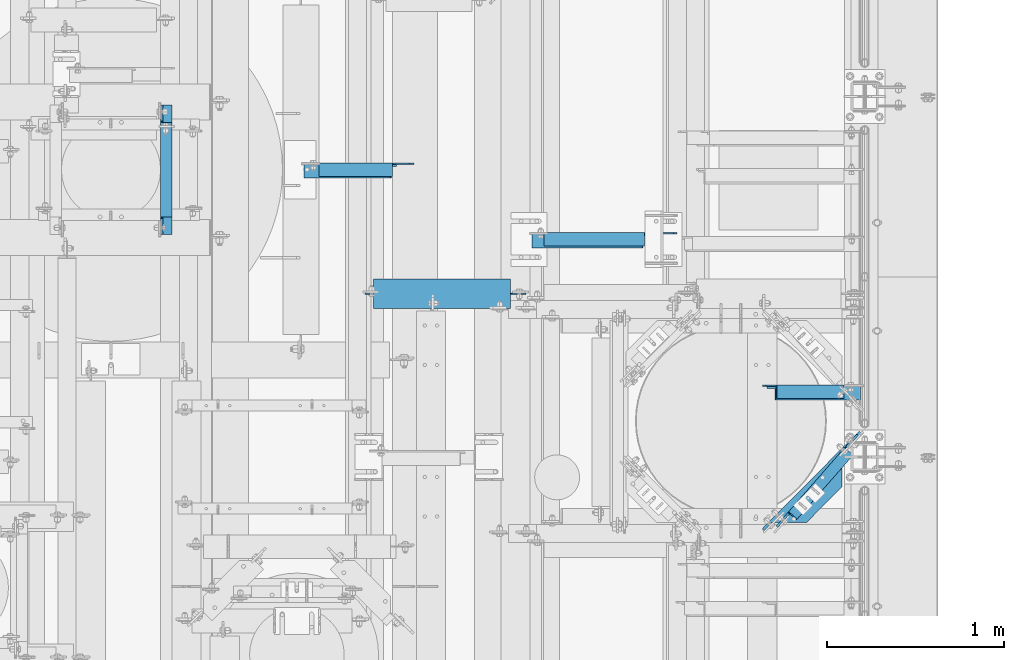
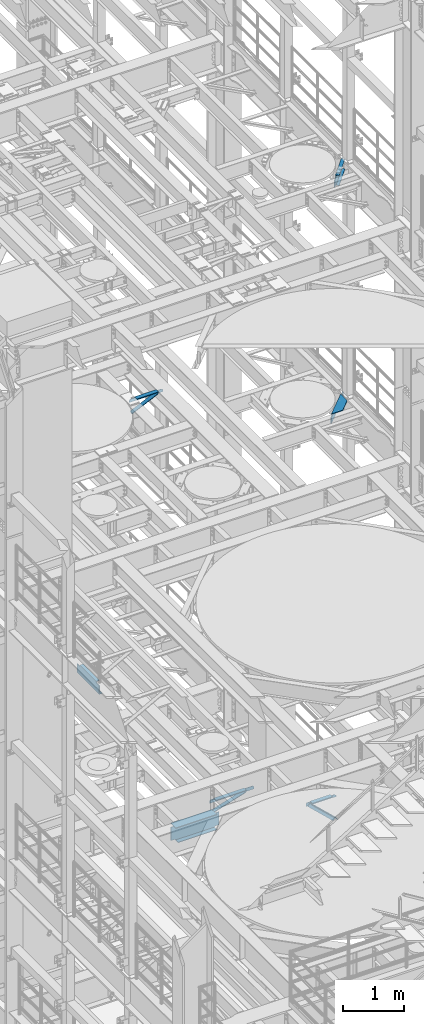
# One storey, part 1261 of 1876: 8 beams, 2 members, 10 elements without a shape of their own.
"""IFC2X3 building model written with IfcOpenShell, lengths in millimetres."""

from ifc_helpers import new_model, si_unit, frame, origin_with_axes, place, context, subcontext, project, spatial, faceted_brep, material, type_object, element, aggregate, save


model = new_model("IFC2X3")

# Units and contexts
model_context = context("Model", 3, precision=1e-05, world=origin_with_axes())
body_context = subcontext(model_context, "Body", "Model", "MODEL_VIEW")
ifc_project = project(units=[si_unit("LENGTHUNIT", "METRE", prefix="MILLI"), si_unit("AREAUNIT", "SQUARE_METRE"), si_unit("VOLUMEUNIT", "CUBIC_METRE"), si_unit("MASSUNIT", "GRAM", prefix="KILO"), si_unit("TIMEUNIT", "SECOND"), si_unit("PLANEANGLEUNIT", "RADIAN"), si_unit("SOLIDANGLEUNIT", "STERADIAN"), si_unit("THERMODYNAMICTEMPERATUREUNIT", "DEGREE_CELSIUS"), si_unit("LUMINOUSINTENSITYUNIT", "LUMEN")], contexts=[model_context])

# Site, building, storey
site_placement = place(None, origin_with_axes())
site = spatial("IfcSite", under=ifc_project, at=site_placement, CompositionType="ELEMENT")
building_placement = place(site_placement, origin_with_axes())
building = spatial("IfcBuilding", under=site, at=building_placement, Name="Undefined", CompositionType="ELEMENT")
storey_placement = place(building_placement, origin_with_axes())
storey = spatial("IfcBuildingStorey", under=building, at=storey_placement, Name="Undefined", CompositionType="ELEMENT", Elevation=0.0)

# Assembly, member
assembly_1_placement = place(storey_placement, origin_with_axes())
assembly_1 = element("IfcElementAssembly", 1, at=assembly_1_placement, inside=storey, AssemblyPlace="NOTDEFINED", PredefinedType="RIGID_FRAME")
ifc_material_1 = material(Name="STEEL/A36")
member_type = type_object("IfcMemberType", Name="L3X3X3/8", PredefinedType="NOTDEFINED")
member_1_placement = place(assembly_1_placement, frame((4441.82499954282, 5166.56184844971, 13011.15), z_axis=(0.0, -1.0, 0.0), x_axis=(0.907435344837584, 0.0, 0.420191735924799)))
member_1 = element("IfcMember", 2, at=member_1_placement, type_object=member_type, material=ifc_material_1, ObjectType="L3X3X3/8", context=body_context, shape_type="Brep", body=[
    faceted_brep([(36.0114418339381, 38.0999999999876, -38.1000000000004), (36.0114418339381, 38.0999999999876, 38.1000000000004), (575.098681629477, 38.0999999996493, 38.1000000000004), (575.098681629477, 38.0999999996493, -38.1000000000004), (36.011441833949, 28.5749999999862, 38.1000000000004), (575.098681629484, 28.574999999646, 38.1000000000004), (36.011441833949, 28.5749999999862, -28.5749999999998), (575.098681629484, 28.574999999646, -28.5749999999998), (36.0114418340036, -38.1000000000313, -28.5749999999998), (575.098681629539, -38.1000000003696, -28.5749999999998), (36.0114418340036, -38.1000000000313, -38.1000000000004), (575.098681629539, -38.1000000003696, -38.1000000000004)], [[[0, 1, 2, 3]], [[1, 4, 5, 2]], [[4, 6, 7, 5]], [[6, 8, 9, 7]], [[8, 10, 11, 9]], [[10, 0, 3, 11]], [[5, 7, 9, 11, 3, 2]], [[10, 8, 6, 4, 1, 0]]]),
])
aggregate(assembly_1, [member_1])

assembly_2_placement = place(storey_placement, origin_with_axes())
assembly_2 = element("IfcElementAssembly", 3, at=assembly_2_placement, inside=storey, AssemblyPlace="NOTDEFINED", PredefinedType="RIGID_FRAME")
member_2_placement = place(assembly_2_placement, frame((7042.14884555327, 3914.775, 5130.79999999686), z_axis=(0.0, -1.0, 0.0), x_axis=(0.726792308030797, 0.0, -0.686857293029104)))
member_2 = element("IfcMember", 4, at=member_2_placement, type_object=member_type, material=ifc_material_1, ObjectType="L3X3X3/8", context=body_context, shape_type="Brep", body=[
    faceted_brep([(72.6727188348357, 38.100000000004, -38.0999999999999), (72.6727188348357, 38.100000000004, 38.0999999999999), (731.760828651386, 38.1000000001059, 38.0999999999999), (731.760828651386, 38.1000000001059, -38.0999999999999), (72.6727188348361, 28.5750000000062, 38.0999999999999), (731.760828651386, 28.5750000001062, 38.0999999999999), (72.6727188348361, 28.5750000000062, -28.5749999999998), (731.760828651386, 28.5750000001062, -28.5749999999998), (72.6727188348361, -38.0999999999822, -28.5749999999998), (731.760828651387, -38.0999999998821, -28.5749999999998), (72.6727188348361, -38.0999999999822, -38.0999999999999), (731.760828651387, -38.0999999998821, -38.0999999999999)], [[[0, 1, 2, 3]], [[1, 4, 5, 2]], [[4, 6, 7, 5]], [[6, 8, 9, 7]], [[8, 10, 11, 9]], [[10, 0, 3, 11]], [[5, 7, 9, 11, 3, 2]], [[10, 8, 6, 4, 1, 0]]]),
])
aggregate(assembly_2, [member_2])

# Assembly, beam
assembly_3_placement = place(storey_placement, origin_with_axes())
assembly_3 = element("IfcElementAssembly", 5, at=assembly_3_placement, inside=storey, Name="BEAM", AssemblyPlace="NOTDEFINED", PredefinedType="RIGID_FRAME")
ifc_material_2 = material(Name="STEEL/A992")
beam_type_1 = type_object("IfcBeamType", Name="W12X26", PredefinedType="NOTDEFINED")
beam_1_placement = place(assembly_3_placement, frame((4711.7, 4476.75, 4975.225), z_axis=(0.0, 0.0, 1.0), x_axis=(1.0, 0.0, 0.0)))
beam_1 = element("IfcBeam", 6, at=beam_1_placement, type_object=beam_type_1, material=ifc_material_2, Name="BEAM", ObjectType="W12X26", context=body_context, shape_type="Brep", body=[
    faceted_brep([(92.0750001907363, -3.17500000000018, -130.174999999999), (92.0750001907363, 3.17500000000018, -130.174999999999), (168.275000190734, 3.17500000000018, -130.175000000001), (168.275000190734, -3.17500000000018, -130.175000000001), (173.13507970878, 3.17500000000018, -131.141729922589), (173.13507970878, -3.17500000000018, -131.141729922589), (177.255256176933, 3.17500000000018, -133.894743823067), (177.255256176933, -3.17500000000018, -133.894743823067), (180.008270077412, 3.17500000000018, -138.014920291221), (180.008270077412, -3.17500000000018, -138.014920291221), (180.974999999999, -3.17500000000018, -142.874999809266), (180.974999999999, 3.17500000000018, -142.874999809266), (180.974999999999, 3.17500000000018, -146.05), (180.974999999999, 82.5500000000002, -146.05), (180.974999999999, 82.5500000000002, -155.575), (180.974999999999, -82.5500000000002, -155.575), (180.974999999999, -82.5500000000002, -146.05), (180.974999999999, -3.17500000000018, -146.05), (911.225000000001, 82.5500000000002, 146.05), (911.225000000001, 3.17500000000018, 146.05), (139.068453271509, 3.17500000000018, 146.05), (139.068453271509, 82.5500000000002, 146.05), (127.000000190735, -3.17500000000018, 136.525), (127.000000190735, 3.17500000000018, 136.525), (92.0749999999998, 3.17500000000018, 136.525), (92.0749999999998, -3.17500000000018, 136.525), (131.86007970878, -3.17500000000018, 137.491729922587), (131.86007970878, 3.17500000000018, 137.491729922587), (135.980256176934, -3.17500000000018, 140.244743823066), (135.980256176934, 3.17500000000018, 140.244743823066), (138.733270077412, -3.17500000000018, 144.364920291219), (138.733270077412, 3.17500000000018, 144.364920291219), (911.225000000001, -82.5500000000002, 155.575), (911.225000000001, 82.5500000000002, 155.575), (139.7, 82.5500000000002, 155.575), (139.7, -82.5500000000002, 155.575), (139.068453271509, -82.5500000000002, 146.05), (911.225000000001, -82.5500000000002, 146.05), (139.7, -82.5500000000002, 149.224999809265), (911.225000000001, -3.17500000000018, 146.05), (139.068453271509, -3.17500000000018, 146.05), (139.7, 82.5500000000002, 149.224999809265), (911.225000000001, -3.17500000000018, 142.874999809266), (911.225000000001, 3.17500000000018, 142.874999809266), (912.191729922589, -3.17500000000018, 138.014920291221), (912.191729922589, 3.17500000000018, 138.014920291221), (914.944743823067, -3.17500000000018, 133.894743823067), (914.944743823067, 3.17500000000018, 133.894743823067), (919.064920291221, -3.17500000000018, 131.141729922589), (919.064920291221, 3.17500000000018, 131.141729922589), (923.924999809266, -3.17500000000018, 130.175000000001), (923.924999809266, 3.17500000000018, 130.175000000001), (1000.125, -3.17500000000018, 130.175000000001), (1000.125, 3.17500000000018, 130.175000000001), (1000.125, -3.17500000000018, -130.174999999999), (1000.125, 3.17500000000018, -130.174999999999), (923.924999809266, -3.17500000000018, -130.174999999999), (923.924999809266, 3.17500000000018, -130.174999999999), (919.064920291221, -3.17500000000018, -131.141729922587), (919.064920291221, 3.17500000000018, -131.141729922587), (914.944743823067, -3.17500000000018, -133.894743823065), (914.944743823067, 3.17500000000018, -133.894743823065), (912.191729922589, -3.17500000000018, -138.014920291219), (912.191729922589, 3.17500000000018, -138.014920291219), (911.225000000001, -3.17500000000018, -142.874999809264), (911.225000000001, 3.17500000000018, -142.874999809264), (911.225000000001, -3.17500000000018, -146.05), (911.225000000001, -82.5500000000002, -146.05), (911.225000000001, -82.5500000000002, -155.575), (911.225000000001, 82.5500000000002, -155.575), (911.225000000001, 82.5500000000002, -146.05), (911.225000000001, 3.17500000000018, -146.05)], [[[0, 1, 2, 3]], [[3, 2, 4, 5]], [[5, 4, 6, 7]], [[7, 6, 8, 9]], [[10, 11, 12, 13, 14, 15, 16, 17]], [[9, 8, 11, 10]], [[18, 19, 20, 21]], [[22, 23, 24, 25]], [[26, 27, 23, 22]], [[28, 29, 27, 26]], [[30, 31, 29, 28]], [[32, 33, 34, 35]], [[36, 37, 32, 35, 38]], [[39, 37, 36, 40]], [[38, 41, 21, 20, 31, 30, 40, 36]], [[35, 34, 41, 38]], [[33, 18, 21, 41, 34]], [[32, 37, 39, 42, 43, 19, 18, 33]], [[44, 45, 43, 42]], [[46, 47, 45, 44]], [[48, 49, 47, 46]], [[50, 51, 49, 48]], [[52, 53, 51, 50]], [[53, 52, 54, 55]], [[54, 56, 57, 55]], [[58, 59, 57, 56]], [[60, 61, 59, 58]], [[62, 63, 61, 60]], [[64, 65, 63, 62]], [[66, 67, 68, 69, 70, 71, 65, 64]], [[67, 66, 17, 16]], [[68, 67, 16, 15]], [[69, 68, 15, 14]], [[70, 69, 14, 13]], [[71, 70, 13, 12]], [[6, 4, 2, 1, 24, 23, 27, 29, 31, 20, 19, 43, 45, 47, 49, 51, 53, 55, 57, 59, 61, 63, 65, 71, 12, 11, 8]], [[25, 24, 1, 0]], [[66, 64, 62, 60, 58, 56, 54, 52, 50, 48, 46, 44, 42, 39, 40, 30, 28, 26, 22, 25, 0, 3, 5, 7, 9, 10, 17]]]),
])
aggregate(assembly_3, [beam_1])

assembly_4_placement = place(storey_placement, origin_with_axes())
assembly_4 = element("IfcElementAssembly", 7, at=assembly_4_placement, inside=storey, Name="ANGLE", AssemblyPlace="NOTDEFINED", PredefinedType="RIGID_FRAME")
beam_type_2 = type_object("IfcBeamType", Name="L3X3X3/8", PredefinedType="NOTDEFINED")
beam_2_placement = place(assembly_4_placement, frame((4441.82499954281, 5176.08684844971, 13271.5), z_axis=(0.0, -1.0, 0.0), x_axis=(1.0, 0.0, 0.0)))
beam_2 = element("IfcBeam", 8, at=beam_2_placement, type_object=beam_type_2, material=ifc_material_1, Name="ANGLE", ObjectType="L3X3X3/8", context=body_context, shape_type="Brep", body=[
    faceted_brep([(515.938000713418, 28.5750000000007, -28.5749999999998), (515.938001513509, 28.5750000000007, 38.1000000000004), (103.186999799132, 28.5750000000007, 38.0999999999999), (103.186998865692, 28.5750000000007, -28.5749999999998), (515.938001513509, 38.1000000000004, 38.1000000000004), (103.186999799132, 38.1000000000004, 38.0999999999999), (103.186998865692, 22.2250007629391, -28.5749999999998), (103.186998732343, 22.2250007629391, -38.0999999999999), (29.3687518909128, 22.2250007629391, -38.0999999999999), (29.3687520242611, 22.2250007629391, -28.5749999999998), (103.186998732343, 38.1000000000004, -38.0999999999999), (515.938000599119, 38.1000000000004, -38.1000000000004), (515.938000713418, 19.0499996185281, -28.5749999999998), (515.938000599119, 19.0499996185281, -38.1000000000004), (613.568747554848, 19.0499996185281, -28.5749999999998), (613.568747440549, 19.0499996185281, -38.1000000000004), (638.968747173379, -6.35000000000218, -28.5749999999998), (638.96874705908, -6.35000000000218, -38.1000000000004), (638.968750457192, -38.1000000000004, -28.5749999999998), (638.968750457192, -38.1000000000004, -38.1000000000004), (3.96875000000273, -38.1000000000004, -28.5749999999998), (3.96875000000273, -38.1000000000004, -38.0999999999999), (3.96875227238252, -3.17500076293982, -38.0999999999999), (3.96875240573081, -3.17500076293982, -28.5749999999998)], [[[0, 1, 2, 3]], [[1, 4, 5, 2]], [[6, 7, 8, 9]], [[2, 5, 10, 7, 6, 3]], [[4, 11, 10, 5]], [[1, 0, 12, 13, 11, 4]], [[14, 15, 13, 12]], [[15, 14, 16, 17]], [[17, 16, 18, 19]], [[19, 18, 20, 21]], [[8, 7, 10, 11, 13, 15, 17, 19, 21, 22]], [[9, 8, 22, 23]], [[18, 16, 14, 12, 0, 3, 6, 9, 23, 20]], [[22, 21, 20, 23]]]),
])
aggregate(assembly_4, [beam_2])

assembly_5_placement = place(storey_placement, origin_with_axes())
assembly_5 = element("IfcElementAssembly", 9, at=assembly_5_placement, inside=storey, AssemblyPlace="NOTDEFINED", PredefinedType="RIGID_FRAME")
beam_3_placement = place(assembly_5_placement, frame((5727.69996465465, 4773.85557493774, 4867.27500000001), z_axis=(0.0, -1.0, 0.0), x_axis=(0.953964189281616, -1.20000003690115e-08, 0.299920532088533)))
beam_3 = element("IfcBeam", 10, at=beam_3_placement, type_object=beam_type_2, material=ifc_material_1, ObjectType="L3X3X3/8", context=body_context, shape_type="Brep", body=[
    faceted_brep([(28.6194938924073, 38.100000000014, -38.1000000000067), (28.6194938618237, 38.0999999999767, 38.0999999999931), (683.360898815113, 38.0999999999208, 38.0999999999112), (683.360898845696, 38.0999999999581, -38.1000000000895), (28.6194938618237, 28.5749999999771, 38.099999999994), (683.360898815113, 28.5749999999211, 38.0999999999112), (28.6194938885847, 28.5750000000098, -28.5750000000062), (683.360898841872, 28.5749999999539, -28.5750000000889), (28.6194938885847, -38.0999999999854, -28.5750000000035), (683.360898841874, -38.1000000000422, -28.5750000000862), (28.6194938924091, -38.0999999999808, -38.1000000000031), (683.360898845695, -38.1000000000377, -38.1000000000859)], [[[0, 1, 2, 3]], [[1, 4, 5, 2]], [[4, 6, 7, 5]], [[6, 8, 9, 7]], [[8, 10, 11, 9]], [[10, 0, 3, 11]], [[5, 7, 9, 11, 3, 2]], [[10, 8, 6, 4, 1, 0]]]),
])
aggregate(assembly_5, [beam_3])

assembly_6_placement = place(storey_placement, origin_with_axes())
assembly_6 = element("IfcElementAssembly", 11, at=assembly_6_placement, inside=storey, Name="ANGLE", AssemblyPlace="NOTDEFINED", PredefinedType="RIGID_FRAME")
beam_4_placement = place(assembly_6_placement, frame((5727.70004218253, 4783.3805749378, 5092.7), z_axis=(0.0, -1.0, 0.0), x_axis=(1.0, 0.0, 0.0)))
beam_4 = element("IfcBeam", 12, at=beam_4_placement, type_object=beam_type_2, material=ifc_material_1, Name="ANGLE", ObjectType="L3X3X3/8", context=body_context, shape_type="Brep", body=[
    faceted_brep([(84.137014014791, 28.5749999999998, 38.1000000000258), (84.1373129237786, 38.0999999999985, 38.0999999999835), (84.1373049986182, 38.0999999999985, -38.1000000000167), (84.1369574531245, 26.9870094055223, -38.099999999974), (84.1369575769495, 26.9870083863452, -28.5749999999744), (84.1370606917826, 28.5750000000007, -28.5749999999771), (22.2249551643299, 26.9870094055232, -38.0999999999931), (22.2249552881549, 26.9870083863452, -28.5749999999935), (3.17495592726937, 7.93701016846171, -38.0999999999995), (3.17495605109434, 7.93700914928468, -28.5749999999989), (3.17495592726937, 1.58700978699198, -38.0999999999995), (3.17495605109434, 1.58700876781495, -28.5749999999989), (3.17492999904698, -38.0999999999985, -38.1000000000013), (3.17493098964678, -38.0999999999985, -28.5750000000012), (835.024961298736, 7.93700065612848, -28.5749999997352), (815.974962061676, 26.986999893189, -28.5749999997415), (652.461957758697, 26.986999893189, -28.5749999997934), (652.461957758697, 28.5749999999998, -28.5749999997934), (835.024957576975, -38.1000000000004, -28.5749999997352), (835.024961298736, 1.58700027465875, -28.5749999997352), (652.461959158867, 28.5749999999998, 38.1000000002068), (652.461959158867, 38.1000000000004, 38.1000000002068), (652.461957558674, 38.1000000000004, -38.099999999793), (652.461957558674, 26.986999893189, -38.099999999793), (815.974961861652, 26.986999893189, -38.0999999997421), (835.024961098713, 7.93700065612848, -38.0999999997357), (835.024961098713, 1.58700027465875, -38.0999999997357), (835.02495745315, -38.1000000000004, -38.0999999997357)], [[[0, 1, 2, 3, 4, 5]], [[4, 3, 6, 7]], [[7, 6, 8, 9]], [[9, 8, 10, 11]], [[10, 12, 13, 11]], [[14, 15, 16, 17, 5, 4, 7, 9, 11, 13, 18, 19]], [[0, 5, 17, 20]], [[1, 0, 20, 21]], [[2, 1, 21, 22]], [[20, 17, 16, 23, 22, 21]], [[15, 24, 23, 16]], [[14, 25, 24, 15]], [[19, 26, 25, 14]], [[12, 10, 8, 6, 3, 2, 22, 23, 24, 25, 26, 27]], [[13, 12, 27, 18]], [[26, 19, 18, 27]]]),
])
aggregate(assembly_6, [beam_4])

assembly_7_placement = place(storey_placement, origin_with_axes())
assembly_7 = element("IfcElementAssembly", 13, at=assembly_7_placement, inside=storey, Name="ANGLE", AssemblyPlace="NOTDEFINED", PredefinedType="RIGID_FRAME")
beam_5_placement = place(assembly_7_placement, frame((7042.14884547182, 3924.3, 5092.69999999686), z_axis=(0.0, -1.0, 0.0), x_axis=(1.0, 0.0, 0.0)))
beam_5 = element("IfcBeam", 14, at=beam_5_placement, type_object=beam_type_2, material=ifc_material_1, Name="ANGLE", ObjectType="L3X3X3/8", context=body_context, shape_type="Brep", body=[
    faceted_brep([(461.964154830203, 28.5749999999998, -28.5749999999998), (461.964155696969, 28.5749999999998, 38.0999999999999), (84.1379236981738, 28.5750017148421, 38.1000000000004), (84.1379497680955, 28.5749999999998, -28.5749999999998), (461.964155696969, 38.1000000000004, 38.0999999999999), (84.1382986980861, 38.1000000000004, 38.0999999999999), (22.2259474792336, 28.5749999999998, -28.5749999999998), (22.225951203508, 28.5750108588118, -38.0999999999999), (3.17595196644379, 9.5250116217494, -38.0999999999999), (3.1759482421694, 9.52501047875285, -28.5749999999998), (84.1379534923708, 28.5750108588145, -38.0999999999999), (84.1383284919229, 38.1000000000004, -38.0999999999999), (461.96415470638, 38.1000000000004, -38.0999999999999), (461.964154830171, 12.6999992401979, -28.5749999999998), (461.964154706342, 12.6999992401979, -38.0999999999999), (538.957410445405, 12.6999992401979, -28.5749999999998), (538.957410321576, 12.6999992401979, -38.0999999999999), (570.707410445405, -19.0500007598021, -28.5749999999998), (570.707410321576, -19.0500007598021, -38.0999999999999), (570.707404528182, -38.1000000000004, -28.5749999999998), (570.707404528182, -38.1000000000004, -38.0999999999999), (3.17594976805049, -38.1000000000004, -28.5749999999998), (3.17595349232579, -38.1000000000004, -38.0999999999999), (3.17595196644379, 3.17501219395399, -38.0999999999999), (3.17594824216849, 3.17501105095744, -28.5749999999998)], [[[0, 1, 2, 3]], [[1, 4, 5, 2]], [[6, 7, 8, 9]], [[3, 10, 7, 6]], [[2, 5, 11, 10, 3]], [[4, 12, 11, 5]], [[1, 0, 13, 14, 12, 4]], [[15, 16, 14, 13]], [[16, 15, 17, 18]], [[18, 17, 19, 20]], [[20, 19, 21, 22]], [[8, 7, 10, 11, 12, 14, 16, 18, 20, 22, 23]], [[9, 8, 23, 24]], [[19, 17, 15, 13, 0, 3, 6, 9, 24, 21]], [[23, 22, 21, 24]]]),
])
aggregate(assembly_7, [beam_5])

assembly_8_placement = place(storey_placement, origin_with_axes())
assembly_8 = element("IfcElementAssembly", 15, at=assembly_8_placement, inside=storey, Name="BEAM", AssemblyPlace="NOTDEFINED", PredefinedType="RIGID_FRAME")
beam_type_3 = type_object("IfcBeamType", Name="C8X18.75", PredefinedType="NOTDEFINED")
beam_6_placement = place(assembly_8_placement, frame((3683.0, 4794.25, 8051.8), z_axis=(0.0, 0.0, 1.0), x_axis=(0.0, 1.0, 0.0)))
beam_6 = element("IfcBeam", 16, at=beam_6_placement, type_object=beam_type_3, material=ifc_material_1, Name="BEAM", ObjectType="C8X18.75", context=body_context, shape_type="Brep", body=[
    faceted_brep([(648.493749999994, -31.75, 101.6), (648.493749999994, -31.75, 97.3645500000002), (648.493749999994, 19.0500000000002, 88.9012700000003), (648.493749999994, 19.0500000000002, 82.5499998092655), (648.493749999994, 31.75, 82.5499998092655), (648.493749999994, 31.75, 101.6), (649.460479922582, 19.0500000000002, 77.68992029122), (649.460479922582, 31.75, 77.68992029122), (652.21349382306, 19.0500000000002, 73.5697438230663), (652.21349382306, 31.75, 73.5697438230663), (656.333670291214, 19.0500000000002, 70.8167299225879), (656.333670291214, 31.75, 70.8167299225879), (661.193749809259, 19.0500000000002, 69.8500000000004), (661.193749809259, 31.75, 69.8500000000004), (745.331249999993, 19.0500000000002, 69.8500000000004), (745.331249999993, 31.75, 69.8500000000004), (113.50625, -31.75, 101.6), (113.50625, 31.75, 101.6), (113.50625, 31.75, 82.5499998092655), (113.50625, 19.0500000000002, 82.5499998092655), (113.50625, 19.0500000000002, 88.9012700000003), (113.50625, -31.75, 97.3645500000002), (112.539520077413, 31.75, 77.68992029122), (112.539520077413, 19.0500000000002, 77.68992029122), (109.786506176934, 31.75, 73.5697438230663), (109.786506176934, 19.0500000000002, 73.5697438230663), (105.666329708781, 31.75, 70.8167299225879), (105.666329708781, 19.0500000000002, 70.8167299225879), (100.806250190735, 31.75, 69.8500000000004), (100.806250190735, 19.0500000000002, 69.8500000000004), (16.6687499999998, 31.75, 69.8500000000004), (16.6687499999998, 19.0500000000002, 69.8500000000004), (16.6687499999998, 31.75, -101.6), (16.6687499999998, -31.75, -101.6), (16.6687499999998, -31.75, -97.3645500000002), (16.6687499999998, 19.0500000000002, -88.9012700000003), (745.331249999993, 31.75, -101.6), (745.331249999993, -31.75, -101.6), (745.331249999993, -31.75, -97.3645500000002), (745.331249999993, 19.0500000000002, -88.9012700000003)], [[[0, 1, 2, 3, 4, 5]], [[6, 7, 4, 3]], [[8, 9, 7, 6]], [[10, 11, 9, 8]], [[12, 13, 11, 10]], [[14, 15, 13, 12]], [[16, 17, 18, 19, 20, 21]], [[19, 18, 22, 23]], [[23, 22, 24, 25]], [[25, 24, 26, 27]], [[27, 26, 28, 29]], [[29, 28, 30, 31]], [[32, 33, 34, 35, 31, 30]], [[33, 32, 36, 37]], [[34, 33, 37, 38]], [[35, 34, 38, 39]], [[10, 8, 6, 3, 2, 20, 19, 23, 25, 27, 29, 31, 35, 39, 14, 12]], [[21, 20, 2, 1]], [[16, 21, 1, 0]], [[17, 16, 0, 5]], [[36, 32, 30, 28, 26, 24, 22, 18, 17, 5, 4, 7, 9, 11, 13, 15]], [[39, 38, 37, 36, 15, 14]]]),
])
aggregate(assembly_8, [beam_6])

assembly_9_placement = place(storey_placement, origin_with_axes())
assembly_9 = element("IfcElementAssembly", 17, at=assembly_9_placement, inside=storey, Name="BEAM", AssemblyPlace="NOTDEFINED", PredefinedType="RIGID_FRAME")
beam_7_placement = place(assembly_9_placement, frame((7135.76341397225, 3136.74451276421, 17881.6), z_axis=(0.0, 0.0, 1.0), x_axis=(0.658504607797722, 0.752576694768825, 0.0)))
beam_7 = element("IfcBeam", 18, at=beam_7_placement, type_object=beam_type_3, material=ifc_material_1, Name="BEAM", ObjectType="C8X18.75", context=body_context, shape_type="Brep", body=[
    faceted_brep([(599.994793902918, -31.750000000161, 101.599999999999), (599.994793902832, -31.7500000001605, 97.3645499999984), (599.994793902845, 19.0499999998497, 88.9012699999985), (599.994793902865, 19.0499999998488, 69.8499990463133), (599.994793902852, 31.7499999998522, 69.8499990463133), (599.994793902852, 31.7499999998522, 101.599999999999), (600.961523825454, 19.0499999998492, 64.9899195282669), (600.96152382544, 31.7499999998522, 64.9899195282669), (603.714537725932, 19.0499999998488, 60.8697430601133), (603.714537725919, 31.7499999998508, 60.8697430601133), (607.834714194088, 19.0499999998474, 58.1167291596357), (607.834714194075, 31.7499999998504, 58.1167291596357), (612.694793712136, 19.0499999998465, 57.1499992370482), (612.694793712123, 31.749999999849, 57.1499992370482), (701.595364581624, 19.0499999998237, 57.1499992370482), (701.59536458184, 31.7499999998258, 57.1499992370482), (121.106195622893, -31.7500000000373, 101.599999999991), (121.106195622828, 31.7499999999759, 101.599999999999), (121.106195622828, 31.7499999999759, 82.5499998092564), (121.106195622841, 19.0499999999724, 82.5499998092564), (121.106195622821, 19.0499999999734, 88.9012699999985), (121.106195622808, -31.7500000000368, 97.3645499999984), (120.13946570024, 31.7499999999754, 77.68992029121), (120.139465700252, 19.0499999999738, 77.68992029121), (117.386451799761, 31.7499999999768, 73.5697438230563), (117.386451799773, 19.0499999999738, 73.5697438230563), (113.266275331604, 31.7499999999782, 70.8167299225788), (113.266275331617, 19.0499999999747, 70.8167299225788), (108.406195813556, 31.7499999999782, 69.8499999999913), (108.40619581357, 19.0499999999765, 69.8499999999913), (13.1564438477099, 31.7500000000036, 69.8499999999913), (13.1564438477262, 19.0500000000006, 69.8499999999913), (13.1564438477099, 31.7500000000036, -69.8500000000095), (13.1564438477262, 19.0500000000006, -69.8500000000095), (102.05669486356, 31.7499999999809, -69.8500000000095), (102.056694863572, 19.0499999999779, -69.8500000000095), (106.916774381608, 31.7499999999791, -70.816729922597), (106.916774381621, 19.0499999999774, -70.816729922597), (111.036950849764, 31.7499999999777, -73.5697438230782), (111.036950849778, 19.0499999999761, -73.5697438230782), (113.789964750244, 31.7499999999773, -77.6899202912318), (113.789964750255, 19.0499999999747, -77.6899202912318), (114.75669467283, 31.7499999999773, -82.5499998092782), (114.756694672843, 19.0499999999747, -82.5499998092782), (599.995201963808, -31.750000000161, -101.599999999999), (599.995201963808, -31.750000000161, -97.3645499999984), (114.756694672807, -31.7500000000359, -97.3645499999984), (114.75669467289, -31.7500000000364, -101.599999999999), (599.995201963821, 18.4499999996992, -101.599999999999), (599.995201963821, 18.4499999996992, -89.0012300000235), (114.756694672821, 19.0499999999747, -88.9012699999985), (599.995038410477, 19.0499999998497, -88.9012699999985), (114.756694672825, 31.7499999999773, -101.599999999999), (599.995201963726, 31.7499999998522, -101.599999999999), (599.994956611298, 31.7499999998522, -82.5501633571148), (599.994956611312, 19.0499999998501, -82.5501633607164), (600.961639585345, 31.7499999998518, -77.690033612198), (600.961639585358, 19.0499999998492, -77.6900336158033), (603.714642597415, 31.7499999998513, -73.5698016375063), (603.714642597429, 19.0499999998488, -73.5698016411079), (607.834839111108, 31.7499999998499, -70.8167455541079), (607.834839111121, 19.0499999998474, -70.8167455577131), (612.694956404054, 31.7499999998486, -69.849999978167), (612.694956404066, 19.049999999846, -69.8499999817723), (701.595363726707, 19.0499999998233, -69.8499998734842), (701.59536458184, 31.7499999998258, -69.8499998698826)], [[[0, 1, 2, 3, 4, 5]], [[6, 7, 4, 3]], [[8, 9, 7, 6]], [[10, 11, 9, 8]], [[12, 13, 11, 10]], [[14, 15, 13, 12]], [[16, 17, 18, 19, 20, 21]], [[19, 18, 22, 23]], [[23, 22, 24, 25]], [[25, 24, 26, 27]], [[27, 26, 28, 29]], [[29, 28, 30, 31]], [[32, 33, 31, 30]], [[33, 32, 34, 35]], [[35, 34, 36, 37]], [[37, 36, 38, 39]], [[39, 38, 40, 41]], [[41, 40, 42, 43]], [[44, 45, 46, 47]], [[45, 44, 48, 49]], [[50, 46, 45, 49, 51]], [[43, 42, 52, 47, 46, 50]], [[44, 47, 52, 53, 48]], [[51, 49, 48, 53, 54, 55]], [[55, 54, 56, 57]], [[57, 56, 58, 59]], [[59, 58, 60, 61]], [[61, 60, 62, 63]], [[64, 63, 62, 65]], [[10, 8, 6, 3, 2, 20, 19, 23, 25, 27, 29, 31, 33, 35, 37, 39, 41, 43, 50, 51, 55, 57, 59, 61, 63, 64, 14, 12]], [[21, 20, 2, 1]], [[16, 21, 1, 0]], [[17, 16, 0, 5]], [[65, 62, 60, 58, 56, 54, 53, 52, 42, 40, 38, 36, 34, 32, 30, 28, 26, 24, 22, 18, 17, 5, 4, 7, 9, 11, 13, 15]], [[64, 65, 15, 14]]]),
])
aggregate(assembly_9, [beam_7])

assembly_10_placement = place(storey_placement, origin_with_axes())
assembly_10 = element("IfcElementAssembly", 19, at=assembly_10_placement, inside=storey, Name="BEAM", AssemblyPlace="NOTDEFINED", PredefinedType="RIGID_FRAME")
beam_type_4 = type_object("IfcBeamType", Name="L6X6X5/8", PredefinedType="NOTDEFINED")
beam_8_placement = place(assembly_10_placement, frame((7069.18666985838, 3070.52725414415, 13233.4), z_axis=(0.709836241819047, -0.704366743820441, 0.0), x_axis=(0.704366743820441, 0.709836241819047, 0.0)))
beam_8 = element("IfcBeam", 20, at=beam_8_placement, type_object=beam_type_4, material=ifc_material_1, Name="BEAM", ObjectType="L6X6X5/8", context=body_context, shape_type="Brep", body=[
    faceted_brep([(524.902420162584, 60.3250000000007, 76.1999999998698), (524.902420162584, 76.2000000000007, 76.1999999998698), (240.682965550393, 76.2000000000007, 76.1999999999498), (240.682965550393, 60.3250000000007, 76.1999999999498), (662.487554277177, 60.3250000000007, -60.3250000001995), (105.209931018304, 60.3250000000007, -60.325000000043), (814.618884925258, -76.2000000000007, -76.2000000002458), (814.618884924946, -76.2000000000007, -60.3250000002427), (38.1169915550718, -76.2000000000007, -60.3250000000239), (38.1169915550381, -76.2000000000007, -76.200000000028), (814.618884925258, 38.1000000000004, -76.2000000002458), (814.618884924946, 38.1000000000004, -60.3250000002427), (696.516205343335, 38.1000000000004, -76.2000000002126), (680.517933934671, 38.1000000000004, -60.3250000002045), (689.616277769123, 39.0667299225879, -76.2000000002104), (673.61800636046, 39.0667299225879, -60.3250000002022), (683.766801620086, 41.8197438230654, -76.2000000002095), (667.768530211422, 41.8197438230654, -60.3250000002013), (679.858306614281, 45.9399202912191, -76.2000000002076), (663.860035205617, 45.9399202912191, -60.3250000002004), (678.485825685746, 50.7999998092655, -76.2000000002081), (662.487554277082, 50.7999998092655, -60.3250000001999), (678.485825685851, 76.2000000000007, -76.2000000002076), (89.4572525843396, 76.2000000000007, -76.2000000000426), (89.4572525842805, 57.1499998092659, -76.2000000000421), (105.209931018235, 57.1499998092659, -60.3250000000435), (38.1169915550381, 44.4500000000007, -76.200000000028), (71.5658023298975, 44.4500000000007, -76.2000000000367), (78.4125639232343, 45.4167299225883, -76.2000000000394), (84.2169681300338, 48.1697438230658, -76.2000000000407), (88.095347026866, 52.2899202912195, -76.2000000000426), (94.1652423571886, 45.4167299225883, -60.3250000000407), (87.3184807638518, 44.4500000000007, -60.325000000038), (99.9696465639872, 48.1697438230658, -60.3250000000421), (103.848025460819, 52.2899202912195, -60.325000000043), (38.1169915550718, 44.4500000000007, -60.3250000000239)], [[[0, 1, 2, 3]], [[4, 0, 3, 5]], [[6, 7, 8, 9]], [[7, 6, 10, 11]], [[11, 10, 12, 13]], [[14, 15, 13, 12]], [[16, 17, 15, 14]], [[18, 19, 17, 16]], [[20, 21, 19, 18]], [[22, 1, 0, 4, 21, 20]], [[1, 22, 23, 2]], [[3, 2, 23, 24, 25, 5]], [[22, 20, 18, 16, 14, 12, 10, 6, 9, 26, 27, 28, 29, 30, 24, 23]], [[31, 28, 27, 32]], [[33, 29, 28, 31]], [[34, 30, 29, 33]], [[25, 24, 30, 34]], [[33, 31, 32, 35, 8, 7, 11, 13, 15, 17, 19, 21, 4, 5, 25, 34]], [[9, 8, 35, 26]], [[32, 27, 26, 35]]]),
])
aggregate(assembly_10, [beam_8])

save(model, "model.ifc")
